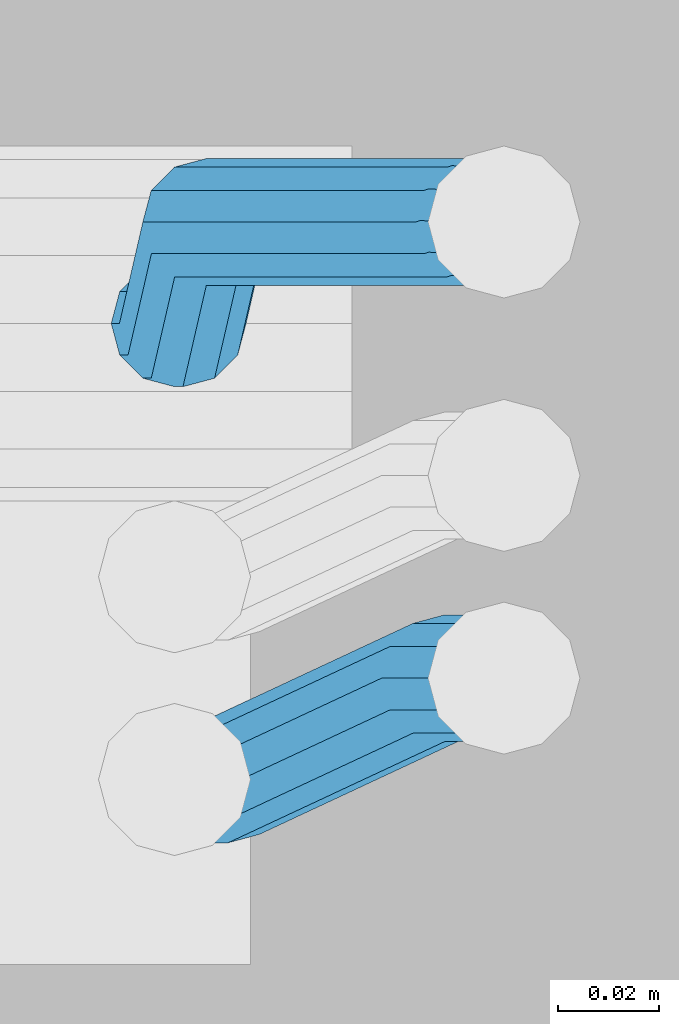
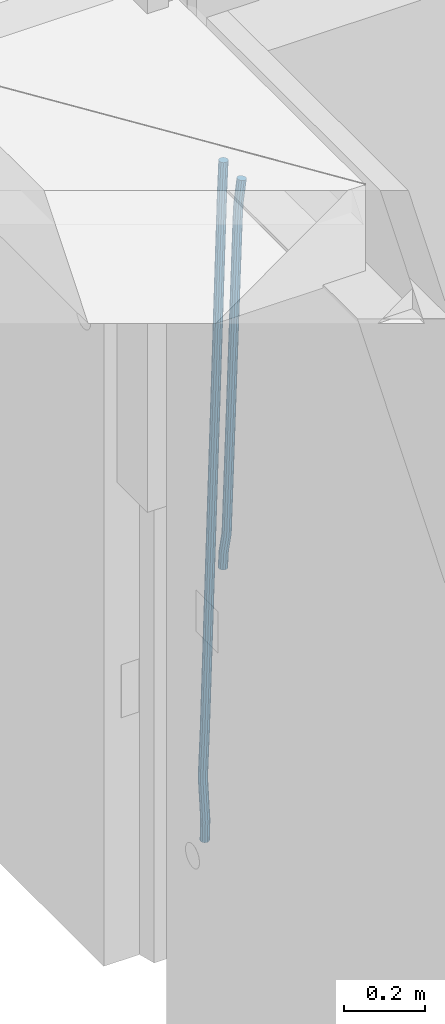
# One storey, part 121 of 352: 2 beams, 1 element without a shape of its own.
"""IFC2X3 building model written with IfcOpenShell, lengths in millimetres."""

from ifc_helpers import new_model, si_unit, frame, origin_with_axes, place, context, subcontext, project, spatial, faceted_brep, material, type_object, element, aggregate, save


model = new_model("IFC2X3")

# Units and contexts
model_context = context("Model", 3, precision=1e-05, world=origin_with_axes())
body_context = subcontext(model_context, "Body", "Model", "MODEL_VIEW")
ifc_project = project(units=[si_unit("LENGTHUNIT", "METRE", prefix="MILLI"), si_unit("AREAUNIT", "SQUARE_METRE"), si_unit("VOLUMEUNIT", "CUBIC_METRE"), si_unit("MASSUNIT", "GRAM", prefix="KILO"), si_unit("TIMEUNIT", "SECOND"), si_unit("PLANEANGLEUNIT", "RADIAN"), si_unit("SOLIDANGLEUNIT", "STERADIAN"), si_unit("THERMODYNAMICTEMPERATUREUNIT", "DEGREE_CELSIUS"), si_unit("LUMINOUSINTENSITYUNIT", "LUMEN")], contexts=[model_context])

# Site, building, storey
site_placement = place(None, origin_with_axes())
site = spatial("IfcSite", under=ifc_project, at=site_placement, CompositionType="ELEMENT")
building_placement = place(site_placement, origin_with_axes())
building = spatial("IfcBuilding", under=site, at=building_placement, CompositionType="ELEMENT")
storey_placement = place(building_placement, origin_with_axes())
storey = spatial("IfcBuildingStorey", under=building, at=storey_placement, Name="6", CompositionType="ELEMENT", Elevation=0.0)

# Assembly, beams
assembly_placement = place(storey_placement, origin_with_axes())
assembly = element("IfcElementAssembly", 1, at=assembly_placement, inside=storey, AssemblyPlace="NOTDEFINED", PredefinedType="REINFORCEMENT_UNIT")
ifc_material = material()
beam_type = type_object("IfcBeamType", Name="D25", PredefinedType="NOTDEFINED")
beam_1_placement = place(assembly_placement, frame((17644.9989431251, 20116.4982803956, 98267.5035525011), z_axis=(0.0, 1.0, 0.0), x_axis=(0.0467115440025518, 0.0, 0.998908420055061)))
beam_1 = element("IfcBeam", 2, at=beam_1_placement, type_object=beam_type, material=ifc_material, Name="JM25", ObjectType="D25", context=body_context, shape_type="Brep", body=[
    faceted_brep([(-7.41420080885291e-08, -12.5, -3.63797880709171e-12), (-6.42030499875546e-08, -10.8253175473074, -6.25000000000364), (48.7743672639481, -10.8253174221936, -6.25), (48.7743672682554, -12.4999998748863, 0.0), (-3.70782800018787e-08, -6.25000000000364, -10.8253175473074), (48.7743672522192, -6.24999987488263, -10.8253175473037), (-1.45519152283669e-11, -3.63797880709171e-12, -12.5), (48.7743672361976, 1.25113729154691e-07, -12.5), (3.70637280866504e-08, 6.25, -10.8253175473074), (48.7743672201614, 6.25000012511737, -10.8253175473037), (6.42030499875546e-08, 10.8253175473001, -6.25000000000364), (48.774367208418, 10.8253176724174, -6.25), (7.41420080885291e-08, 12.4999999999927, 0.0), (48.7743672041252, 12.5000001251174, 0.0), (6.42176019027829e-08, 10.8253175473001, 6.24999999999636), (48.774367208418, 10.8253176724174, 6.25), (3.70928319171071e-08, 6.24999999999636, 10.8253175473037), (48.7743672201614, 6.25000012511737, 10.8253175473037), (1.45519152283669e-11, -3.63797880709171e-12, 12.4999999999964), (48.7743672361976, 1.25113729154691e-07, 12.5), (-3.7049176171422e-08, -6.25000000000364, 10.8253175473001), (48.7743672522192, -6.24999987488263, 10.8253175473037), (-6.41884980723262e-08, -10.8253175473074, 6.25), (48.7743672639481, -10.8253174221936, 6.25), (50.6284132863948, -10.8253174174351, -6.25), (50.7256294211547, -12.4999998698804, 0.0), (50.362813866901, -6.2499998708081, -10.8253175473037), (49.9999983126327, 1.28262399812229e-07, -12.5), (49.6371827583935, 6.25000012732926, -10.8253175473037), (49.3715833388851, 10.8253176739527, -6.25), (49.2743672041252, 12.5000001264016, 0.0), (49.3715833388851, 10.8253176739527, 6.25), (49.6371827583935, 6.25000012732926, 10.8253175473037), (49.9999983126327, 1.28262399812229e-07, 12.5), (50.362813866901, -6.2499998708081, 10.8253175473037), (50.6284132863948, -10.8253174174351, 6.25), (52.4700055286376, -10.6107838149001, -6.25), (52.6637847850943, -12.2742172873113, 0.0), (51.9405907545442, -6.0661990532717, -10.8253175473037), (51.2173967239651, 0.141819180764287, -12.5), (50.494202693415, 6.34983741480755, -10.8253175473037), (49.9647879192926, 10.8944221764359, -6.25), (49.7710086628358, 12.5578556488472, 0.0), (49.9647879192926, 10.8944221764359, 6.25), (50.494202693415, 6.34983741480755, 10.8253175473037), (51.2173967239651, 0.141819180764287, 12.5), (51.9405907545442, -6.0661990532717, 10.8253175473037), (52.4700055286376, -10.6107838149037, 6.25), (100.1682419055, -5.05424733003747, -6.25), (100.362021161956, -6.71768080244692, 0.0), (99.6388271314063, -0.509662568409112, -10.8253175473037), (98.9156331008271, 5.69835566563052, -12.5), (98.192439070277, 11.9063738996665, -10.8253175473037), (97.6630242961546, 16.4509586612985, -6.25), (97.4692450396979, 18.1143921337098, 0.0), (97.6630242961546, 16.4509586612985, 6.25), (98.192439070277, 11.9063738996665, 10.8253175473037), (98.9156331008271, 5.69835566563052, 12.5), (99.6388271314063, -0.509662568409112, 10.8253175473037), (100.1682419055, -5.05424733003747, 6.25), (100.829389846811, -4.97722786481609, -6.25), (100.858662620667, -6.65982528000313, 0.0), (100.613505361369, -0.39611884945225, -10.8253175473037), (100.268855237926, 5.8559973049887, -12.5), (99.8877881987282, 12.1038711239344, -10.8253175473037), (99.5724108491268, 16.6733898631865, -6.25), (99.4072282953421, 18.3401546667665, 0.0), (99.4365010692127, 16.6575572515831, 6.25), (99.6523855546402, 12.0764482362174, 10.8253175473037), (99.9970356780832, 5.82433208178009, 12.5), (100.37810271731, -0.423541737165579, 10.8253175473037), (100.693480066882, -4.99306047642312, 6.25), (101.494850382805, -4.9772278650471, -6.23547852116099), (101.358543616545, -6.65982528017412, 0.0109082521194068), (101.594541309358, -0.396118849792401, -10.8039096771354), (101.63090429295, 5.85599730451395, -12.4702777768798), (101.594195901474, 12.1038711233377, -10.7880808337759), (101.49425211882, 16.6733898625134, -6.2080621602363), (101.357852800793, 18.340154666088, 0.0425659388420172), (101.221546034547, 16.6575572509591, 6.28895271212241), (101.121855107995, 12.0764482357044, 10.8573838680968), (101.085492124403, 5.82433208139992, 12.5237519678412), (101.122200515863, -0.423541737425694, 10.8415550247373), (101.222144298532, -4.99306047660866, 6.26153635119772), (1016.15234243186, -4.97722818425427, 13.7239010304511), (1016.01603566563, -6.65982559938311, 19.9702878037351), (1016.25203335841, -0.396119168995938, 9.15546987447669), (1016.28839634202, 5.85599698530859, 7.48910177473226), (1016.25168795056, 12.1038708041378, 9.17129871783618), (1016.15174416787, 16.6733895433135, 13.7513173913758), (1016.01534484986, 18.3401543468826, 20.0019454904541), (1015.8790380836, 16.6575569317556, 26.2483322637381), (1015.77934715705, 12.0764479165045, 30.8167634197125), (1015.74298417347, 5.82433176219456, 32.4831315194569), (1015.77969256493, -0.423542056632868, 30.8009345763494), (1015.8796363476, -4.99306079580856, 26.2209159028134), (1016.72024271244, -4.97722818445254, 13.7362935788587), (1016.65208128402, -6.65982559960139, 19.984167399125), (1016.77009392806, -0.396119169179656, 9.16677483576495), (1016.7882773379, 5.85599698513579, 7.50001002685531), (1016.76992071191, 12.1038708039559, 9.18260743664359), (1016.71994269331, 16.6733895431171, 13.7637164479929), (1016.65173485172, 18.3401543466607, 20.015832600875), (1016.58357342328, 16.65755693151, 26.2637064211413), (1016.53372220766, 12.0764479162353, 30.833225164235), (1016.51553879784, 5.82433176192717, 32.4999899731447), (1016.53389542381, -0.423542056894803, 30.8173925633564), (1016.58387344243, -4.99306079605594, 26.2362835520071), (1017.28827819017, -4.97722813975997, 13.7362935788587), (1017.28827832255, -6.6598255495519, 19.984167399125), (1017.28827782976, -0.396119128414284, 9.16677483576495), (1017.28827733788, 5.85599702447144, 7.50001002685531), (1017.28827684635, 12.103870844734, 9.18260743664359), (1017.28827648686, 16.6733895878278, 13.7637164479929), (1017.28827635571, 18.3401543967448, 20.015832600875), (1017.28827648809, 16.657556986951, 26.2637064211413), (1017.2882768485, 12.0764479756035, 30.833225164235), (1017.28827734038, 5.8243318227178, 32.4999899731447), (1017.28827783192, -0.423541997544817, 30.8173925633564), (1017.28827819142, -4.99306074063679, 26.2362835520071), (1065.6667756622, -4.97722433367016, 13.7362935788587), (1065.66677579457, -6.65982174345845, 19.984167399125), (1065.6667753018, -0.3961153223172, 9.16677483576495), (1065.66677480991, 5.85600083056488, 7.50001002685531), (1065.66677431838, 12.1038746508275, 9.18260743664359), (1065.66677395887, 16.6733933939249, 13.7637164479929), (1065.66677382775, 18.3401582028346, 20.015832600875), (1065.66677396011, 16.6575607930445, 26.2637064211413), (1065.66677432053, 12.0764517816933, 30.833225164235), (1065.6667748124, 5.82433562881488, 32.4999899731447), (1065.66677530395, -0.423538191451371, 30.8173925633564), (1065.66677566344, -4.99305693454517, 26.2362835520071), (1067.07165110651, -4.97722422314291, 13.7362935788587), (1067.13694763639, -6.65982162779255, 19.984167399125), (1066.89387208481, -0.396115225779795, 9.16677483576495), (1066.6512463166, 5.85600090801745, 7.50001002685531), (1066.40878518049, 12.1038747092061, 9.18260743664359), (1066.23145594214, 16.6733934383519, 13.7637164479929), (1066.16677382775, 18.340158242172, 20.015832600875), (1066.23207035761, 16.6575608375188, 26.2637064211413), (1066.40984937931, 12.0764518401556, 30.833225164235), (1066.65247514757, 5.82433570636204, 32.4999899731447), (1066.89493628364, -0.423538094826654, 30.8173925633564), (1067.07226552199, -4.99305682397062, 26.2362835520071), (1068.47230333716, -4.86837412698696, 13.736334784764), (1068.60269804588, -6.54588751704068, 19.9842150143704), (1068.11728165975, -0.301059828409052, 9.16679859123906), (1067.63276078545, 5.93224720081525, 7.50000996663584), (1067.14856769117, 12.161337376032, 9.18258357686864), (1066.79444152558, 16.7171310152116, 13.7636751818718), (1066.66527010873, 18.3789068918468, 20.0157849856296), (1066.79566481744, 16.7013935018003, 26.263665215236), (1067.15068649485, 12.134079203217, 30.8332014087609), (1067.63520736917, 5.90077217399266, 32.4999900333642), (1068.11940046342, -0.328318001224034, 30.8174164231314), (1068.47352662902, -4.88411164040008, 26.2363248181282), (1142.62319484423, 0.89544508106701, 13.736334784764), (1142.75358955294, -0.782068308983071, 19.9842150143704), (1142.26817316683, 5.4627593796431, 9.16679859123906), (1141.78365229251, 11.6960664088729, 7.50000996663584), (1141.29945919824, 17.9251565840896, 9.18258357686864), (1140.94533303265, 22.4809502232638, 13.7636751818718), (1140.81616161579, 24.1427260999008, 20.0157849856296), (1140.94655632452, 22.4652127098525, 26.263665215236), (1141.30157800192, 17.8978984112746, 30.8332014087609), (1141.78609887623, 11.6645913820466, 32.4999900333642), (1142.27029197049, 5.43550120682994, 30.8174164231314), (1142.6244181361, 0.879707567652076, 26.2363248181282)], [[[0, 1, 2, 3]], [[1, 4, 5, 2]], [[4, 6, 7, 5]], [[6, 8, 9, 7]], [[8, 10, 11, 9]], [[10, 12, 13, 11]], [[12, 14, 15, 13]], [[14, 16, 17, 15]], [[16, 18, 19, 17]], [[18, 20, 21, 19]], [[20, 22, 23, 21]], [[22, 0, 3, 23]], [[22, 20, 18, 16, 14, 12, 10, 8, 6, 4, 1, 0]], [[3, 2, 24, 25]], [[2, 5, 26, 24]], [[5, 7, 27, 26]], [[7, 9, 28, 27]], [[9, 11, 29, 28]], [[11, 13, 30, 29]], [[13, 15, 31, 30]], [[15, 17, 32, 31]], [[17, 19, 33, 32]], [[19, 21, 34, 33]], [[21, 23, 35, 34]], [[23, 3, 25, 35]], [[25, 24, 36, 37]], [[24, 26, 38, 36]], [[26, 27, 39, 38]], [[27, 28, 40, 39]], [[28, 29, 41, 40]], [[29, 30, 42, 41]], [[30, 31, 43, 42]], [[31, 32, 44, 43]], [[32, 33, 45, 44]], [[33, 34, 46, 45]], [[34, 35, 47, 46]], [[35, 25, 37, 47]], [[37, 36, 48, 49]], [[36, 38, 50, 48]], [[38, 39, 51, 50]], [[39, 40, 52, 51]], [[40, 41, 53, 52]], [[41, 42, 54, 53]], [[42, 43, 55, 54]], [[43, 44, 56, 55]], [[44, 45, 57, 56]], [[45, 46, 58, 57]], [[46, 47, 59, 58]], [[47, 37, 49, 59]], [[49, 48, 60, 61]], [[48, 50, 62, 60]], [[50, 51, 63, 62]], [[51, 52, 64, 63]], [[52, 53, 65, 64]], [[53, 54, 66, 65]], [[54, 55, 67, 66]], [[55, 56, 68, 67]], [[56, 57, 69, 68]], [[57, 58, 70, 69]], [[58, 59, 71, 70]], [[59, 49, 61, 71]], [[61, 60, 72, 73]], [[60, 62, 74, 72]], [[62, 63, 75, 74]], [[63, 64, 76, 75]], [[64, 65, 77, 76]], [[65, 66, 78, 77]], [[66, 67, 79, 78]], [[67, 68, 80, 79]], [[68, 69, 81, 80]], [[69, 70, 82, 81]], [[70, 71, 83, 82]], [[71, 61, 73, 83]], [[73, 72, 84, 85]], [[72, 74, 86, 84]], [[74, 75, 87, 86]], [[75, 76, 88, 87]], [[76, 77, 89, 88]], [[77, 78, 90, 89]], [[78, 79, 91, 90]], [[79, 80, 92, 91]], [[80, 81, 93, 92]], [[81, 82, 94, 93]], [[82, 83, 95, 94]], [[83, 73, 85, 95]], [[85, 84, 96, 97]], [[84, 86, 98, 96]], [[86, 87, 99, 98]], [[87, 88, 100, 99]], [[88, 89, 101, 100]], [[89, 90, 102, 101]], [[90, 91, 103, 102]], [[91, 92, 104, 103]], [[92, 93, 105, 104]], [[93, 94, 106, 105]], [[94, 95, 107, 106]], [[95, 85, 97, 107]], [[97, 96, 108, 109]], [[96, 98, 110, 108]], [[98, 99, 111, 110]], [[99, 100, 112, 111]], [[100, 101, 113, 112]], [[101, 102, 114, 113]], [[102, 103, 115, 114]], [[103, 104, 116, 115]], [[104, 105, 117, 116]], [[105, 106, 118, 117]], [[106, 107, 119, 118]], [[107, 97, 109, 119]], [[109, 108, 120, 121]], [[108, 110, 122, 120]], [[110, 111, 123, 122]], [[111, 112, 124, 123]], [[112, 113, 125, 124]], [[113, 114, 126, 125]], [[114, 115, 127, 126]], [[115, 116, 128, 127]], [[116, 117, 129, 128]], [[117, 118, 130, 129]], [[118, 119, 131, 130]], [[119, 109, 121, 131]], [[121, 120, 132, 133]], [[120, 122, 134, 132]], [[122, 123, 135, 134]], [[123, 124, 136, 135]], [[124, 125, 137, 136]], [[125, 126, 138, 137]], [[126, 127, 139, 138]], [[127, 128, 140, 139]], [[128, 129, 141, 140]], [[129, 130, 142, 141]], [[130, 131, 143, 142]], [[131, 121, 133, 143]], [[133, 132, 144, 145]], [[132, 134, 146, 144]], [[134, 135, 147, 146]], [[135, 136, 148, 147]], [[136, 137, 149, 148]], [[137, 138, 150, 149]], [[138, 139, 151, 150]], [[139, 140, 152, 151]], [[140, 141, 153, 152]], [[141, 142, 154, 153]], [[142, 143, 155, 154]], [[143, 133, 145, 155]], [[145, 144, 156, 157]], [[144, 146, 158, 156]], [[146, 147, 159, 158]], [[147, 148, 160, 159]], [[148, 149, 161, 160]], [[149, 150, 162, 161]], [[150, 151, 163, 162]], [[151, 152, 164, 163]], [[152, 153, 165, 164]], [[153, 154, 166, 165]], [[154, 155, 167, 166]], [[155, 145, 157, 167]], [[158, 159, 160, 161, 162, 163, 164, 165, 166, 167, 157, 156]]]),
])
beam_2_placement = place(assembly_placement, frame((17645.0, 20206.4982799665, 97390.0), z_axis=(0.999642804629538, 0.000205762999925497, -0.0267249099901003), x_axis=(0.0267249109941254, -4.30000210532798e-08, 0.999642825779465)))
beam_2 = element("IfcBeam", 3, at=beam_2_placement, type_object=beam_type, material=ifc_material, Name="JM25", ObjectType="D25", context=body_context, shape_type="Brep", body=[
    faceted_brep([(-7.41420080885291e-08, -12.5, -3.63797880709171e-12), (-6.42030499875546e-08, -10.8253175473074, -6.25000000000364), (59.4220778053423, -10.8253175324608, -6.25000005319089), (59.4220778086747, -12.4999999851534, -5.3194526117295e-08), (-3.70782800018787e-08, -6.25000000000364, -10.8253175473074), (59.4220778020681, -6.24999998515341, -10.8253176004946), (-1.45519152283669e-11, -3.63797880709171e-12, -12.5), (59.4220777997252, 1.48465915117413e-08, -12.5000000531927), (3.70637280866504e-08, 6.25, -10.8253175473074), (59.422077798954, 6.25000001485023, -10.8253176004982), (6.42030499875546e-08, 10.8253175473001, -6.25000000000364), (59.4220777999435, 10.8253175621539, -6.25000005319089), (7.41420080885291e-08, 12.4999999999927, 0.0), (59.4220778024173, 12.5000000148466, -5.31908881384879e-08), (6.42176019027829e-08, 10.8253175473001, 6.24999999999636), (59.4220778057497, 10.8253175621576, 6.24999994680911), (3.70928319171071e-08, 6.24999999999636, 10.8253175473037), (59.4220778090239, 6.25000001485023, 10.8253174941128), (1.45519152283669e-11, -3.63797880709171e-12, 12.4999999999964), (59.4220778113668, 1.48465915117413e-08, 12.4999999468128), (-3.7049176171422e-08, -6.25000000000364, 10.8253175473001), (59.4220778121526, -6.24999998515705, 10.8253174941183), (-6.41884980723262e-08, -10.8253175473074, 6.25), (59.422077811163, -10.8253175324571, 6.24999994680547), (60.1059015733626, -10.8253175322861, -6.25000005380571), (59.9220778086747, -12.4999999850261, -5.36383595317602e-08), (60.5270973313018, -6.24999998487692, -10.8253176014878), (61.0728060192778, 1.52613210957497e-08, -12.5000000546715), (61.5968054350378, 6.25000001539229, -10.8253176024446), (61.9586903583258, 10.825317562787, -6.25000005546281), (62.0614940161613, 12.5000000155051, -5.55555743630975e-08), (61.8776702514588, 10.8253175627651, 6.24999994460995), (61.4564744935342, 6.25000001535955, 10.8253174922938), (60.9107658055436, 1.52213033288717e-08, 12.4999999454776), (60.3867663897981, -6.2499999849133, 10.8253174932506), (60.0248814664956, -10.825317532308, 6.24999994626887), (60.7797257564671, -10.9415004936782, -6.24120031120765), (60.4147662867617, -12.5849509379113, 0.00643416450657242), (61.6159581115353, -6.43774490879878, -10.8110977280703), (62.6993955677171, -0.280461855141766, -12.4787577637399), (63.739731933616, 5.88050964549984, -10.7973322583985), (64.4582099200925, 10.3943422549237, -6.21735781835014), (64.6623139309086, 12.0515581706859, 0.03396510384664), (64.2973544612178, 10.4081077264564, 6.28159957956086), (63.461122106135, 5.90435214157333, 10.8514969964235), (62.3776846499532, -0.252930912083684, 12.5191570320894), (61.3373482840689, -6.41390241272165, 10.8377315267553), (60.6188702975924, -10.9277350221564, 6.25775708670699), (173.678050556482, -30.407797550004, -4.76681541592006), (173.313091086762, -32.0512479942336, 1.4808190597978), (174.514282911536, -25.9040419651246, -9.33671283278272), (175.597720367718, -19.7467589114676, -11.0043728684504), (176.638056733602, -13.585787410826, -9.32294736311087), (177.356534720093, -9.0719548013949, -4.74297292306073), (177.560638730924, -7.41473888563996, 1.50834999913423), (177.195679261218, -9.05818932986585, 7.75598447485027), (176.35944690615, -13.5619449147489, 12.3258818917166), (175.276009449968, -19.7192279684059, 13.9935419273806), (174.235673084069, -25.8801994690475, 12.3121164220465), (173.517195097593, -30.3940320784823, 7.73214198199094), (176.138237106381, -30.8319909317906, -4.73468684452382), (175.913853754129, -32.499679968274, 1.51478347157899), (176.589132212815, -26.2617942428296, -9.30961653639861), (177.145722093832, -20.0136704134529, -10.98415688768), (177.658868940271, -13.7617991779516, -9.30961616354944), (177.991075469021, -9.18136438506554, -4.73468619872801), (178.053327209011, -7.49968983852159, 1.5147842172828), (177.828943856759, -9.16737887500858, 7.76425453338925), (177.37804875031, -13.7375755639696, 12.3391842252604), (176.821458869294, -19.9856993933463, 14.0137245765418), (176.308312022869, -26.237570628844, 12.3391838524112), (175.976105494119, -30.8180054217337, 7.76425388758798), (178.634722048839, -30.8318743800774, -4.70223538057326), (178.552989161486, -32.4996730848652, 1.54907076560085), (178.694593853957, -26.2615981169292, -9.28219734144659), (178.71656197503, -20.0134461293128, -10.9636180082289), (178.694740071747, -13.7616056964944, -9.29596207112627), (178.634975305482, -9.18125241366579, -4.72607659172718), (178.553281597095, -7.49968824400275, 1.52154130624513), (178.471548709742, -9.16748694879061, 7.7728474524265), (178.411676904623, -13.7377632119424, 12.3528094132944), (178.389708783536, -19.9859151995588, 14.0342300800785), (178.411530686833, -26.23775563237, 12.3665741429741), (178.471295453099, -30.8181089152022, 7.79668866358043), (319.488626215083, -30.8314939674237, -2.86053540860667), (319.406893327759, -32.499292672208, 3.39077073757289), (319.548498020216, -26.261217704272, -7.44049736947818), (319.570466141289, -20.0130657166519, -9.12191803626411), (319.548644237992, -13.7612252838408, -7.45426209915786), (319.488879471741, -9.18087200101581, -2.88437661976423), (319.407185763353, -7.4993078313455, 3.36324127821172), (319.325452876015, -9.167106536137, 9.61454742438946), (319.265581070882, -13.7373827992851, 14.1945093852592), (319.243612949809, -19.9855347868979, 15.8759300520433), (319.265434853078, -26.2373752197163, 14.2082741149388), (319.325199619343, -30.8177285025449, 9.63838863554338), (320.017443228702, -30.8314925392151, -2.85362099409576), (319.964532372032, -32.4992911661575, 3.39806200733256), (320.056202037245, -26.2612163330814, -7.43385901266629), (320.070423406214, -20.013064366387, -9.11538097016819), (320.056296731302, -13.7612239127957, -7.44762441603234), (320.01760724363, -9.18087057304729, -2.87746337211138), (319.964721760145, -7.4993063255788, 3.37053120060227), (319.91181090349, -9.16710495252482, 9.62221420203059), (319.873052094961, -13.7373811586476, 14.2024522205975), (319.858830725978, -19.9855331253457, 15.8839741781048), (319.87295740089, -26.2373735789442, 14.2162176239653), (319.911646888577, -30.8177269186926, 9.64605658004257), (320.546301518712, -30.8314921215424, -2.85158332608989), (320.522214942423, -32.4992907257256, 3.40021073403295), (320.563945682734, -26.2612159320888, -7.431902698474), (320.570419694937, -20.0130639715098, -9.1134545062032), (320.563988849026, -13.7612235118395, -7.44566830037184), (320.546376284925, -9.1808701554437, -2.87542604797454), (320.522301275021, -7.49930588522329, 3.37267953023547), (320.498214698731, -9.16710448940648, 9.62447359036014), (320.480570534695, -13.7373806788601, 14.2047929627461), (320.474096522506, -19.9855326394354, 15.8863447704753), (320.480527368418, -26.2373730991094, 14.2185585646439), (320.498139932504, -30.8177264555052, 9.64831631225024), (1894.35323904471, -30.8302491939103, 3.21222639639745), (1894.32915246842, -32.4980477980898, 9.46402045652394), (1894.37088320871, -26.2599730044531, -1.36809297598302), (1894.37735722095, -20.0118210438777, -3.04964478371585), (1894.37092637502, -13.7599805842037, -1.38185857788449), (1894.35331381093, -9.1796272278043, 3.18838367451281), (1894.32923880102, -7.4980629575839, 9.43648925272464), (1894.30515222471, -9.16586156176709, 15.6882833128511), (1894.2875080607, -13.7361377512207, 20.2686026852371), (1894.28103404849, -19.9842897117996, 21.9501544929644), (1894.2874648944, -26.2361301714736, 20.2823682871331), (1894.30507745848, -30.8164835278658, 15.7121260347358), (1894.91223858956, -30.8302487524343, 3.21438019734705), (1894.84772318714, -32.4980473885444, 9.46601848696628), (1894.98133310449, -26.2599725223481, -1.36574093906893), (1895.03649291246, -20.0118205233157, -3.04710516254454), (1895.06293798747, -13.7599800376811, -1.37919228721876), (1895.05358239301, -9.17962667476604, 3.19108177892304), (1895.01093295308, -7.49806241920669, 9.43911579066662), (1894.94641755069, -9.16586105532406, 15.6907540802767), (1894.87732303573, -13.7361372854102, 20.2708752166945), (1894.82216322777, -19.984289284439, 21.9522394401702), (1894.79571815276, -26.2361297700772, 20.284326564848), (1894.80507374721, -30.8164831329887, 15.7140524987026), (1895.47114527243, -30.837537004496, 3.22181869265842), (1895.36620776, -32.5048085284143, 9.47291900396158), (1895.59168159126, -26.267931585553, -1.35761780421126), (1895.69551910722, -20.0204143533228, -3.03833417552232), (1895.75483464175, -13.7690025048832, -1.36998382688762), (1895.75373464527, -9.18875679657504, 3.20040011310266), (1895.69251386097, -7.50695036707475, 9.44818695861068), (1895.58757634854, -9.17422189099307, 15.699287269912), (1895.4670400297, -13.7438273099324, 20.2787237667835), (1895.36320251375, -19.9913445421626, 21.9594401380946), (1895.30388697921, -26.2427563905985, 20.2910897894599), (1895.30498697569, -30.823002098914, 15.720705849466), (1917.25744196717, -31.1216345590001, 3.51177275974987), (1917.15250445475, -32.788906082922, 9.7628730710494), (1917.37797828601, -26.5520291400608, -1.0676637371198), (1917.48181580196, -20.3045119078306, -2.7483801084345), (1917.5411313365, -14.0531000593946, -1.08002975979252), (1917.54003134, -9.47285435107915, 3.49035418019412), (1917.47881055571, -7.7910479215825, 9.73814102570577), (1917.37387304328, -9.45831944550082, 15.9892413370071), (1917.25333672446, -14.0279248644365, 20.5686778338786), (1917.14949920849, -20.2754420966667, 22.2493942051933), (1917.09018367396, -26.5268539451099, 20.5810438565477), (1917.09128367042, -31.1070996534218, 16.0106599165647), (1917.94316974688, -31.1305765828838, 3.52089911846269), (1917.85264237775, -32.7980360178735, 9.77219121452072), (1918.02633208608, -26.5604837999635, -1.05903478912296), (1918.0798461137, -20.3123103396429, -2.7404209163069), (1918.08937278928, -14.0602492347753, -1.07273320814602), (1918.05235944779, -9.47953520944429, 3.49717276072806), (1917.9787237842, -7.79756688750422, 9.74479437647096), (1917.88819641506, -9.46502632249758, 15.9960864725308), (1917.80503407588, -14.0351191054142, 20.5760203801128), (1917.75152004823, -20.2832925657385, 22.257406507304), (1917.74199337266, -26.5353536706025, 20.5897187991395), (1917.77900671415, -31.1160676959298, 16.0198128302654), (1918.62895550129, -31.1285475281402, 3.52982218347461), (1918.55283939735, -32.795947999115, 9.78130547352521), (1918.67474087057, -26.5585779185749, -1.05060823136955), (1918.67792735249, -20.3105588367471, -2.73266314035027), (1918.63766113177, -14.0586419499232, -1.06563728897891), (1918.56473150974, -9.47802333907384, 3.50379109209644), (1918.47867991975, -7.79607606181162, 9.75124735830832), (1918.40256381579, -9.46347653279008, 16.0027306483644), (1918.35677844651, -14.0334461423481, 20.5831610632049), (1918.35359196461, -20.2814652241759, 22.2652159721838), (1918.39385818531, -26.5333821109998, 20.5981901208143), (1918.46678780734, -31.1140007218564, 16.0287617397316), (2018.62971518922, -30.8303462840922, 4.82693655916046), (2018.5535990853, -32.4977467550671, 11.0784198492183), (2018.67550055851, -26.2603766745233, 0.246506144323575), (2018.67868704045, -20.0123575926991, -1.43554876465714), (2018.63842081973, -13.7604407058789, 0.231477086710584), (2018.5654911977, -9.17982209502588, 4.80090546778956), (2018.47943960771, -7.49787481776366, 11.0483617339996), (2018.40332350375, -9.16527528874212, 17.2998450240593), (2018.35753813446, -13.7352448983038, 21.880275438898), (2018.35435165254, -19.9832639801316, 23.5623303478787), (2018.39461787326, -26.2351808669555, 21.8953044965092), (2018.46754749528, -30.8157994778048, 17.3258761154248)], [[[0, 1, 2, 3]], [[1, 4, 5, 2]], [[4, 6, 7, 5]], [[6, 8, 9, 7]], [[8, 10, 11, 9]], [[10, 12, 13, 11]], [[12, 14, 15, 13]], [[14, 16, 17, 15]], [[16, 18, 19, 17]], [[18, 20, 21, 19]], [[20, 22, 23, 21]], [[22, 0, 3, 23]], [[22, 20, 18, 16, 14, 12, 10, 8, 6, 4, 1, 0]], [[3, 2, 24, 25]], [[2, 5, 26, 24]], [[5, 7, 27, 26]], [[7, 9, 28, 27]], [[9, 11, 29, 28]], [[11, 13, 30, 29]], [[13, 15, 31, 30]], [[15, 17, 32, 31]], [[17, 19, 33, 32]], [[19, 21, 34, 33]], [[21, 23, 35, 34]], [[23, 3, 25, 35]], [[25, 24, 36, 37]], [[24, 26, 38, 36]], [[26, 27, 39, 38]], [[27, 28, 40, 39]], [[28, 29, 41, 40]], [[29, 30, 42, 41]], [[30, 31, 43, 42]], [[31, 32, 44, 43]], [[32, 33, 45, 44]], [[33, 34, 46, 45]], [[34, 35, 47, 46]], [[35, 25, 37, 47]], [[37, 36, 48, 49]], [[36, 38, 50, 48]], [[38, 39, 51, 50]], [[39, 40, 52, 51]], [[40, 41, 53, 52]], [[41, 42, 54, 53]], [[42, 43, 55, 54]], [[43, 44, 56, 55]], [[44, 45, 57, 56]], [[45, 46, 58, 57]], [[46, 47, 59, 58]], [[47, 37, 49, 59]], [[49, 48, 60, 61]], [[48, 50, 62, 60]], [[50, 51, 63, 62]], [[51, 52, 64, 63]], [[52, 53, 65, 64]], [[53, 54, 66, 65]], [[54, 55, 67, 66]], [[55, 56, 68, 67]], [[56, 57, 69, 68]], [[57, 58, 70, 69]], [[58, 59, 71, 70]], [[59, 49, 61, 71]], [[61, 60, 72, 73]], [[60, 62, 74, 72]], [[62, 63, 75, 74]], [[63, 64, 76, 75]], [[64, 65, 77, 76]], [[65, 66, 78, 77]], [[66, 67, 79, 78]], [[67, 68, 80, 79]], [[68, 69, 81, 80]], [[69, 70, 82, 81]], [[70, 71, 83, 82]], [[71, 61, 73, 83]], [[73, 72, 84, 85]], [[72, 74, 86, 84]], [[74, 75, 87, 86]], [[75, 76, 88, 87]], [[76, 77, 89, 88]], [[77, 78, 90, 89]], [[78, 79, 91, 90]], [[79, 80, 92, 91]], [[80, 81, 93, 92]], [[81, 82, 94, 93]], [[82, 83, 95, 94]], [[83, 73, 85, 95]], [[85, 84, 96, 97]], [[84, 86, 98, 96]], [[86, 87, 99, 98]], [[87, 88, 100, 99]], [[88, 89, 101, 100]], [[89, 90, 102, 101]], [[90, 91, 103, 102]], [[91, 92, 104, 103]], [[92, 93, 105, 104]], [[93, 94, 106, 105]], [[94, 95, 107, 106]], [[95, 85, 97, 107]], [[97, 96, 108, 109]], [[96, 98, 110, 108]], [[98, 99, 111, 110]], [[99, 100, 112, 111]], [[100, 101, 113, 112]], [[101, 102, 114, 113]], [[102, 103, 115, 114]], [[103, 104, 116, 115]], [[104, 105, 117, 116]], [[105, 106, 118, 117]], [[106, 107, 119, 118]], [[107, 97, 109, 119]], [[109, 108, 120, 121]], [[108, 110, 122, 120]], [[110, 111, 123, 122]], [[111, 112, 124, 123]], [[112, 113, 125, 124]], [[113, 114, 126, 125]], [[114, 115, 127, 126]], [[115, 116, 128, 127]], [[116, 117, 129, 128]], [[117, 118, 130, 129]], [[118, 119, 131, 130]], [[119, 109, 121, 131]], [[121, 120, 132, 133]], [[120, 122, 134, 132]], [[122, 123, 135, 134]], [[123, 124, 136, 135]], [[124, 125, 137, 136]], [[125, 126, 138, 137]], [[126, 127, 139, 138]], [[127, 128, 140, 139]], [[128, 129, 141, 140]], [[129, 130, 142, 141]], [[130, 131, 143, 142]], [[131, 121, 133, 143]], [[133, 132, 144, 145]], [[132, 134, 146, 144]], [[134, 135, 147, 146]], [[135, 136, 148, 147]], [[136, 137, 149, 148]], [[137, 138, 150, 149]], [[138, 139, 151, 150]], [[139, 140, 152, 151]], [[140, 141, 153, 152]], [[141, 142, 154, 153]], [[142, 143, 155, 154]], [[143, 133, 145, 155]], [[145, 144, 156, 157]], [[144, 146, 158, 156]], [[146, 147, 159, 158]], [[147, 148, 160, 159]], [[148, 149, 161, 160]], [[149, 150, 162, 161]], [[150, 151, 163, 162]], [[151, 152, 164, 163]], [[152, 153, 165, 164]], [[153, 154, 166, 165]], [[154, 155, 167, 166]], [[155, 145, 157, 167]], [[157, 156, 168, 169]], [[156, 158, 170, 168]], [[158, 159, 171, 170]], [[159, 160, 172, 171]], [[160, 161, 173, 172]], [[161, 162, 174, 173]], [[162, 163, 175, 174]], [[163, 164, 176, 175]], [[164, 165, 177, 176]], [[165, 166, 178, 177]], [[166, 167, 179, 178]], [[167, 157, 169, 179]], [[169, 168, 180, 181]], [[168, 170, 182, 180]], [[170, 171, 183, 182]], [[171, 172, 184, 183]], [[172, 173, 185, 184]], [[173, 174, 186, 185]], [[174, 175, 187, 186]], [[175, 176, 188, 187]], [[176, 177, 189, 188]], [[177, 178, 190, 189]], [[178, 179, 191, 190]], [[179, 169, 181, 191]], [[181, 180, 192, 193]], [[180, 182, 194, 192]], [[182, 183, 195, 194]], [[183, 184, 196, 195]], [[184, 185, 197, 196]], [[185, 186, 198, 197]], [[186, 187, 199, 198]], [[187, 188, 200, 199]], [[188, 189, 201, 200]], [[189, 190, 202, 201]], [[190, 191, 203, 202]], [[191, 181, 193, 203]], [[194, 195, 196, 197, 198, 199, 200, 201, 202, 203, 193, 192]]]),
])
aggregate(assembly, [beam_1, beam_2])

save(model, "model.ifc")
